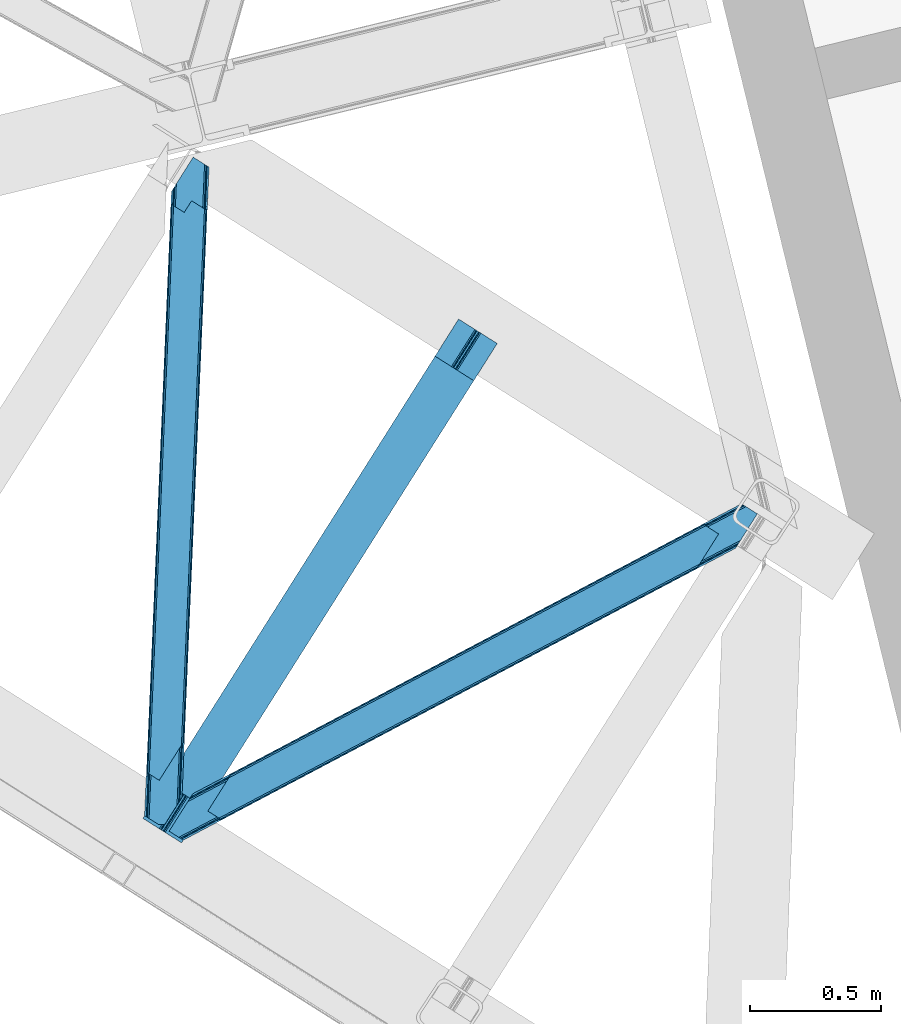
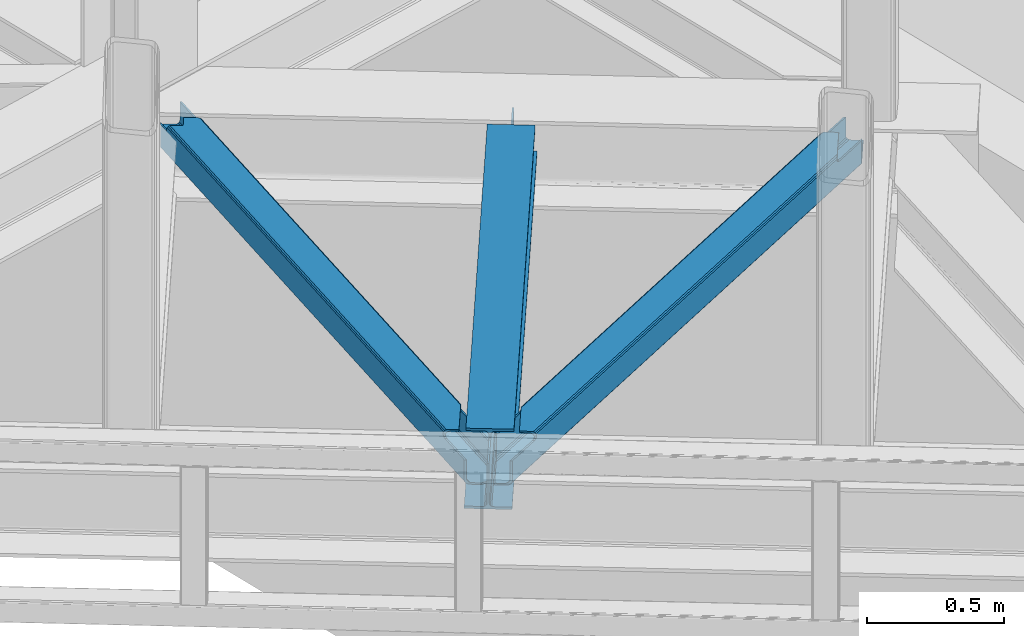
# One storey, part 73 of 92: 2 members, 1 beam.
"""IFC4 building model written with IfcOpenShell, lengths in millimetres."""

import ifcopenshell
import ifcopenshell.guid

model = None  # the IFC model being written
_history = None  # IfcOwnerHistory: only IFC2X3 demands one
_inside = {}  # id of a spatial element -> (the spatial element, [elements in it])
_under = {}  # id of a project, library or spatial element -> (it, [spatial elements below it])
_declared = {}  # id of a project -> (the project, [libraries it declares])
_typed = {}  # id of a type object -> (the type object, [elements of that type])
_made_of = {}  # id of a material, layer set ... -> (it, [elements and type objects made of it])


def new_model(schema):
    """Start an empty IFC model of exactly this schema.

    Asked for "IFC4X3", IfcOpenShell would pick the latest addendum, in which some entities
    have other attributes; the version numbers below select the first issue.
    IFC2X3 requires an IfcOwnerHistory on every rooted entity: one is made here for all.
    """
    global model, _history
    if schema == "IFC4X3":
        model = ifcopenshell.file(schema_version=(4, 3, 0, 0))
    else:
        model = ifcopenshell.file(schema=schema)
    _inside.clear()
    _under.clear()
    _declared.clear()
    _typed.clear()
    _made_of.clear()
    _history = None
    if model.schema == "IFC2X3":
        org = make("IfcOrganization", Name="unknown")
        user = make(
            "IfcPersonAndOrganization",
            ThePerson=make("IfcPerson", FamilyName="unknown"),
            TheOrganization=org,
        )
        app = make(
            "IfcApplication",
            ApplicationDeveloper=org,
            Version="unknown",
            ApplicationFullName="unknown",
            ApplicationIdentifier="unknown",
        )
        _history = make(
            "IfcOwnerHistory",
            OwningUser=user,
            OwningApplication=app,
            ChangeAction="ADDED",
            CreationDate=0,
        )
    return model


def make(cls, **values):
    """One entity of the class cls with the attributes given. An attribute that is None is left unset."""
    return model.create_entity(
        cls, **{name: value for name, value in values.items() if value is not None}
    )


def entity(cls, *values):
    """Any entity or typed value of the class cls, its attributes in the order of the schema. None: left unset."""
    e = model.create_entity(cls)
    for i, value in enumerate(values):
        if value is not None:
            e[i] = value
    return e


def rooted(cls, **values):
    """An entity with a GlobalId (a new one), such as an element, a storey or a relation."""
    return make(cls, GlobalId=ifcopenshell.guid.new(), OwnerHistory=_history, **values)


def si_unit(unit_type, name, prefix=None):
    """IfcSIUnit, for example si_unit("LENGTHUNIT", "METRE", prefix="MILLI")."""
    return make("IfcSIUnit", UnitType=unit_type, Prefix=prefix, Name=name)


def converted_unit(unit_type, name, factor, base, dimensions=None, offset=None):
    """IfcConversionBasedUnit, such as the inch: factor (a typed value) times the base unit."""
    return make(
        "IfcConversionBasedUnit"
        if offset is None
        else "IfcConversionBasedUnitWithOffset",
        ConversionOffset=offset,
        Dimensions=None
        if dimensions is None
        else entity("IfcDimensionalExponents", *dimensions),
        UnitType=unit_type,
        Name=name,
        ConversionFactor=make(
            "IfcMeasureWithUnit", ValueComponent=factor, UnitComponent=base
        ),
    )


def derived_unit(unit_type, elements):
    """IfcDerivedUnit: a product of units, each with its exponent."""
    return make(
        "IfcDerivedUnit",
        Elements=[
            make("IfcDerivedUnitElement", Unit=unit, Exponent=power)
            for unit, power in elements
        ],
        UnitType=unit_type,
    )


def assignment(units):
    """IfcUnitAssignment: the units of a project."""
    return None if units is None else make("IfcUnitAssignment", Units=units)


def point(xyz):
    """IfcCartesianPoint."""
    return None if xyz is None else make("IfcCartesianPoint", Coordinates=xyz)


def direction(xyz):
    """IfcDirection."""
    return None if xyz is None else make("IfcDirection", DirectionRatios=xyz)


def frame(location, z_axis=None, x_axis=None):
    """IfcAxis2Placement3D, a coordinate frame: its origin and axes. An axis left out is left unset."""
    return make(
        "IfcAxis2Placement3D",
        Location=point(location),
        Axis=direction(z_axis),
        RefDirection=direction(x_axis),
    )


def origin():
    """The frame at (0, 0, 0) with its axes left unset."""
    return frame((0.0, 0.0, 0.0))


def place(relative_to, where):
    """IfcLocalPlacement: puts the frame where relative to a parent placement (None: the world)."""
    return make(
        "IfcLocalPlacement", PlacementRelTo=relative_to, RelativePlacement=where
    )


def context(
    kind, dimensions, precision=None, world=None, true_north=None, identifier=None
):
    """IfcGeometricRepresentationContext, for example the 3D "Model" context."""
    return make(
        "IfcGeometricRepresentationContext",
        ContextIdentifier=identifier,
        ContextType=kind,
        CoordinateSpaceDimension=dimensions,
        Precision=precision,
        WorldCoordinateSystem=world,
        TrueNorth=true_north,
    )


def subcontext(parent, identifier, kind, view, scale=None):
    """IfcGeometricRepresentationSubContext, for example "Body" below "Model"."""
    return make(
        "IfcGeometricRepresentationSubContext",
        ContextIdentifier=identifier,
        ContextType=kind,
        ParentContext=parent,
        TargetScale=scale,
        TargetView=view,
    )


def project(units=None, contexts=None):
    """IfcProject with its units and contexts."""
    return rooted(
        "IfcProject",
        Name="project",
        RepresentationContexts=contexts,
        UnitsInContext=assignment(units),
    )


def spatial(cls, under=None, at=None, **own):
    """A site, building, storey or space (cls), placed at a placement, below another one or the project."""
    s = rooted(cls, ObjectPlacement=at, **own)
    if under is not None:
        _under.setdefault(under.id(), (under, []))[1].append(s)
    return s


def point_list(points):
    """IfcCartesianPointList2D or 3D."""
    cls = (
        "IfcCartesianPointList2D" if len(points[0]) == 2 else "IfcCartesianPointList3D"
    )
    return make(cls, CoordList=points)


def triangles(points, corners, closed=None, point_numbers=None):
    """IfcTriangulatedFaceSet: each triangle names its three corners, points numbered from 1."""
    return make(
        "IfcTriangulatedFaceSet",
        Coordinates=point_list(points),
        Closed=closed,
        CoordIndex=corners,
        PnIndex=point_numbers,
    )


def polygons(points, faces, closed=None, point_numbers=None):
    """IfcPolygonalFaceSet: a face is its outer loop, then its inner loops; points numbered from 1."""
    made = []
    for loops in faces:
        if len(loops) == 1:
            made.append(make("IfcIndexedPolygonalFace", CoordIndex=loops[0]))
        else:
            made.append(
                make(
                    "IfcIndexedPolygonalFaceWithVoids",
                    CoordIndex=loops[0],
                    InnerCoordIndices=loops[1:],
                )
            )
    return make(
        "IfcPolygonalFaceSet",
        Coordinates=point_list(points),
        Closed=closed,
        Faces=made,
        PnIndex=point_numbers,
    )


def shape(context_of_items, identifier, shape_type, items):
    """IfcShapeRepresentation: the items that make up one representation, for example the "Body"."""
    return make(
        "IfcShapeRepresentation",
        ContextOfItems=context_of_items,
        RepresentationIdentifier=identifier,
        RepresentationType=shape_type,
        Items=items,
    )


def material(Name=None, Category=None):
    """IfcMaterial."""
    return make("IfcMaterial", Name=Name, Category=Category)


def made_of(thing, what):
    """Note that an element or type object is made of a material, layer set ...; save() writes the relation."""
    if what is not None:
        _made_of.setdefault(what.id(), (what, []))[1].append(thing)
    return thing


def type_object(cls, material=None, **own):
    """A type object (cls), such as IfcWallType, which elements share."""
    return made_of(rooted(cls, **own), material)


def element(
    cls,
    number,
    at=None,
    inside=None,
    cuts=None,
    type_object=None,
    material=None,
    context=None,
    identifier="Body",
    shape_type=None,
    held_by="IfcProductDefinitionShape",
    body=None,
    shapes=None,
    **own,
):
    """One element of the class cls, such as IfcWall. Its Tag is "e" and its number.

    at: its placement. inside: the storey or other place that contains it. cuts: it is an
    opening in that element (IfcRelVoidsElement). A single representation is given by context,
    identifier, shape_type and body (its items); several are given by shapes. held_by: the class
    of the entity that holds the representations. save() writes the other relations.
    """
    e = rooted(cls, Tag="e%d" % number, ObjectPlacement=at, **own)
    if body is not None:
        shapes = [shape(context, identifier, shape_type, body)]
    if shapes is not None:
        e.Representation = make(held_by, Representations=shapes)
    if inside is not None:
        _inside.setdefault(inside.id(), (inside, []))[1].append(e)
    if cuts is not None:
        rooted(
            "IfcRelVoidsElement", RelatingBuildingElement=cuts, RelatedOpeningElement=e
        )
    if type_object is not None:
        _typed.setdefault(type_object.id(), (type_object, []))[1].append(e)
    return made_of(e, material)


def aggregate(whole, parts):
    """IfcRelAggregates: a whole, such as a stair, and the parts it consists of."""
    return rooted("IfcRelAggregates", RelatingObject=whole, RelatedObjects=parts)


def save(model, path):
    """Write the relations noted so far, then the file.

    IfcRelAggregates (storeys below a building ...), IfcRelContainedInSpatialStructure (elements
    in a storey), IfcRelDefinesByType, IfcRelAssociatesMaterial and IfcRelDeclares: one each for
    every whole, place, type object, material and project.
    """
    for whole, parts in _under.values():
        aggregate(whole, parts)
    for where, things in _inside.values():
        rooted(
            "IfcRelContainedInSpatialStructure",
            RelatedElements=things,
            RelatingStructure=where,
        )
    for kind, things in _typed.values():
        rooted("IfcRelDefinesByType", RelatedObjects=things, RelatingType=kind)
    for what, things in _made_of.values():
        rooted("IfcRelAssociatesMaterial", RelatedObjects=things, RelatingMaterial=what)
    for by, libraries in _declared.values():
        rooted("IfcRelDeclares", RelatingContext=by, RelatedDefinitions=libraries)
    model.write(path)


model = new_model("IFC4")

# Units and contexts
model_context = context("Model", 3, precision=0.01, world=origin(), true_north=direction((6.12303176911189e-17, 1.0)))
plan_context = context("Plan", 3, precision=0.01, world=origin(), true_north=direction((6.12303176911189e-17, 1.0)))
body_context = subcontext(model_context, "Body", "Model", "MODEL_VIEW")
ifc_project = project(units=[si_unit("LENGTHUNIT", "METRE", prefix="MILLI"), si_unit("AREAUNIT", "SQUARE_METRE"), si_unit("VOLUMEUNIT", "CUBIC_METRE"), converted_unit("PLANEANGLEUNIT", "DEGREE", entity("IfcRatioMeasure", 0.0174532925199433), si_unit("PLANEANGLEUNIT", "RADIAN"), dimensions=[0, 0, 0, 0, 0, 0, 0]), si_unit("MASSUNIT", "GRAM", prefix="KILO"), derived_unit("MASSDENSITYUNIT", [(si_unit("MASSUNIT", "GRAM", prefix="KILO"), 1), (si_unit("LENGTHUNIT", "METRE"), -3)]), derived_unit("MOMENTOFINERTIAUNIT", [(si_unit("LENGTHUNIT", "METRE"), 4)]), si_unit("TIMEUNIT", "SECOND"), si_unit("FREQUENCYUNIT", "HERTZ"), si_unit("THERMODYNAMICTEMPERATUREUNIT", "DEGREE_CELSIUS"), derived_unit("THERMALTRANSMITTANCEUNIT", [(si_unit("MASSUNIT", "GRAM", prefix="KILO"), 1), (si_unit("THERMODYNAMICTEMPERATUREUNIT", "KELVIN"), -1), (si_unit("TIMEUNIT", "SECOND"), -3)]), derived_unit("VOLUMETRICFLOWRATEUNIT", [(si_unit("LENGTHUNIT", "METRE"), 3), (si_unit("TIMEUNIT", "SECOND"), -1)]), derived_unit("MASSFLOWRATEUNIT", [(si_unit("MASSUNIT", "GRAM", prefix="KILO"), 1), (si_unit("TIMEUNIT", "SECOND"), -1)]), derived_unit("ROTATIONALFREQUENCYUNIT", [(si_unit("TIMEUNIT", "SECOND"), -1)]), si_unit("ELECTRICCURRENTUNIT", "AMPERE"), si_unit("ELECTRICVOLTAGEUNIT", "VOLT"), si_unit("POWERUNIT", "WATT"), si_unit("FORCEUNIT", "NEWTON", prefix="KILO"), si_unit("ILLUMINANCEUNIT", "LUX"), si_unit("LUMINOUSFLUXUNIT", "LUMEN"), si_unit("LUMINOUSINTENSITYUNIT", "CANDELA"), derived_unit("USERDEFINED", [(si_unit("MASSUNIT", "GRAM", prefix="KILO"), -1), (si_unit("LENGTHUNIT", "METRE"), -2), (si_unit("TIMEUNIT", "SECOND"), 3), (si_unit("LUMINOUSFLUXUNIT", "LUMEN"), 1)]), derived_unit("LINEARVELOCITYUNIT", [(si_unit("LENGTHUNIT", "METRE"), 1), (si_unit("TIMEUNIT", "SECOND"), -1)]), si_unit("PRESSUREUNIT", "PASCAL"), derived_unit("USERDEFINED", [(si_unit("LENGTHUNIT", "METRE"), -2), (si_unit("MASSUNIT", "GRAM", prefix="KILO"), 1), (si_unit("TIMEUNIT", "SECOND"), -2)]), derived_unit("LINEARFORCEUNIT", [(si_unit("MASSUNIT", "GRAM", prefix="KILO"), 1), (si_unit("LENGTHUNIT", "METRE"), 1), (si_unit("TIMEUNIT", "SECOND"), -2), (si_unit("LENGTHUNIT", "METRE"), -1)]), derived_unit("PLANARFORCEUNIT", [(si_unit("MASSUNIT", "GRAM", prefix="KILO"), 1), (si_unit("LENGTHUNIT", "METRE"), 1), (si_unit("TIMEUNIT", "SECOND"), -2), (si_unit("LENGTHUNIT", "METRE"), -2)])], contexts=[model_context, plan_context])

# Site, building, storey
site_placement = place(None, origin())
site = spatial("IfcSite", under=ifc_project, at=site_placement, CompositionType="ELEMENT")
building_placement = place(site_placement, origin())
building = spatial("IfcBuilding", under=site, at=building_placement, CompositionType="ELEMENT")
storey_placement = place(building_placement, frame((0.0, 0.0, 15900.0)))
storey = spatial("IfcBuildingStorey", under=building, at=storey_placement, Name="05", CompositionType="ELEMENT", Elevation=15900.0)

# Beam
ifc_material = material(Name="Metal painted (White)")
beam_type = type_object("IfcBeamType", PredefinedType="BEAM")
beam_placement = place(storey_placement, frame((-2373.15, 14260.29, 3441.0)))
element("IfcBeam", 1, at=beam_placement, inside=storey, type_object=beam_type, material=ifc_material, ObjectType="Steel Beam", PredefinedType="BEAM", context=body_context, shape_type="Tessellation", body=[
    polygons([(147.919660694801, 2.16573425859679e-12, 11.000000000004), (147.919660694804, 4.33146851719357e-12, 2.16573425859679e-12), (1355.44607863557, 1910.06544717356, 2.16573425859679e-12), (1355.44607863557, 1910.06544717355, 11.000000000004), (90.4423068248279, 36.3366728266057, 11.0000000000062), (1297.96872476558, 1946.40212000016, 11.0000000000062), (85.2668642219479, 39.6085416920184, 12.2179274798195), (1292.7932821627, 1949.67398886557, 12.2179274798195), (80.879335839855, 42.3822981822298, 15.6862915010278), (1288.40575378062, 1952.44774535578, 15.6862915010235), (77.9476831016699, 44.2356630157985, 20.8770650821592), (1285.47410104242, 1954.30111018934, 20.8770650821592), (76.9182235613, 44.8864781975669, 27.0000000000047), (1284.44464150205, 1954.95192537111, 27.0000000000025), (1278.52785507426, 1958.69246522089, 27.0000000000047), (1278.52785507432, 1958.69246522022, 203.000000000006), (1284.44464150196, 1954.95192537085, 203.000000000006), (1207.52641794078, 2003.57894341848, 2.16573425859679e-12), (1207.52641794077, 2003.57894341847, 10.9999999999997), (1265.00377181074, 1967.24227059188, 11.000000000004), (1270.17921441362, 1963.97040172646, 12.2179274798174), (1274.56674279571, 1961.19664523624, 15.686291501017), (1277.49839553388, 1959.34328040268, 20.8770650821613), (76.9182235613823, 44.8864781975192, 203.000000000006), (71.0014371335516, 48.6270180473361, 203.000000000006), (71.0014371335062, 48.6270180473665, 27.0000000000047), (69.9719775931376, 49.2778332291413, 20.8770650821657), (67.0403248549568, 51.1311980626949, 15.686291501017), (62.6527964728682, 53.904954552915, 12.2179274798174), (57.4773538699869, 57.176823418332, 11.000000000004), (8.12150346973795e-12, 93.5134962449225, 10.9999999999997), (5.41433564649196e-12, 93.5134962449269, 2.16573425859679e-12), (162.887980343835, 180.873386503032, 203.069792575797), (1195.07248712349, 1813.58297531797, 203.006342981534), (1194.53809439775, 1812.73773730252, 217.000000000003), (163.217821525431, 181.395193639939, 217.000000000003), (163.217821525544, 181.395193639874, 204.000000000014), (156.766642341062, 184.290495421957, 203.006342980148), (157.301035097542, 185.135733489758, 217.000000000003), (1188.62130797009, 1816.4782771522, 217.000000000003), (1188.6213079702, 1816.47827715213, 204.00000000001), (1188.95114918025, 1817.00008434255, 203.069791966823), (157.301035097816, 185.135733489578, 204.000000000014), (164.247281065643, 180.744378458268, 223.122934917846), (167.178933803825, 178.891013624723, 228.313708498988), (171.566462185928, 176.117257134518, 231.782072520181), (176.741904788822, 172.845388269138, 232.999999999999), (234.219258658959, 136.508715442803, 233.000000000003), (234.219258658962, 136.508715442803, 244.000000000005), (86.2995979637529, 230.022211687052, 244.000000000005), (86.2995979637521, 230.022211687052, 232.999999999999), (143.776951833897, 193.685538860712, 233.000000000003), (148.952394436777, 190.413669995315, 231.78207252019), (153.339922818875, 187.63991350511, 228.313708498988), (156.271575557062, 185.786548671563, 223.12293491785), (1187.59184842946, 1817.12909233409, 223.12293491785), (1184.66019569129, 1818.98245716763, 228.313708498988), (1180.27266730917, 1821.75621365784, 231.78207252019), (1175.0972247063, 1825.02808252324, 233.000000000003), (1117.61987083616, 1861.36475534957, 232.999999999999), (1117.61987083616, 1861.36475534957, 244.000000000005), (1265.53953153138, 1767.85125910532, 244.000000000005), (1265.53953153137, 1767.85125910532, 233.000000000003), (1208.06217766123, 1804.18793193166, 233.000000000003), (1202.88673505832, 1807.45980079704, 231.782072520181), (1198.49920667623, 1810.23355728724, 228.313708498988), (1195.56755393804, 1812.08692212079, 223.122934917842), (1194.53809439802, 1812.73773730233, 204.00000000001)], [[[1, 2, 3, 4]], [[5, 1, 4, 6]], [[7, 5, 6, 8]], [[9, 7, 8, 10]], [[11, 9, 10, 12]], [[13, 11, 12, 14]], [[15, 16, 17, 14, 12, 10, 8, 6, 4, 3, 18, 19, 20, 21, 22, 23]], [[13, 24, 25, 26, 27, 28, 29, 30, 31, 32, 2, 1, 5, 7, 9, 11]], [[2, 32, 18, 3]], [[32, 31, 19, 18]], [[31, 30, 20, 19]], [[27, 26, 15, 23]], [[28, 27, 23, 22]], [[29, 28, 22, 21]], [[30, 29, 21, 20]], [[33, 24, 13, 14, 17, 34, 35, 36, 37]], [[25, 38, 39, 40, 41, 42, 16, 15, 26]], [[38, 25, 24, 33]], [[42, 34, 17, 16]], [[39, 43, 37, 36, 44, 45, 46, 47, 48, 49, 50, 51, 52, 53, 54, 55]], [[40, 56, 57, 58, 59, 60, 61, 62, 63, 64, 65, 66, 67, 35, 68, 41]], [[44, 36, 35, 67]], [[45, 44, 67, 66]], [[46, 45, 66, 65]], [[47, 46, 65, 64]], [[48, 47, 64, 63]], [[49, 48, 63, 62]], [[50, 49, 62, 61]], [[51, 50, 61, 60]], [[52, 51, 60, 59]], [[53, 52, 59, 58]], [[54, 53, 58, 57]], [[55, 54, 57, 56]], [[39, 55, 56, 40]]], closed=False),
])

# Members
member_type_1 = type_object("IfcMemberType", PredefinedType="BRACE")
member_1_placement = place(storey_placement, frame((-2272.78, 14270.52, 3541.0)))
element("IfcMember", 2, at=member_1_placement, inside=storey, type_object=member_type_1, ObjectType="Steel Horizontal Brace", PredefinedType="BRACE", context=body_context, shape_type="Tessellation", body=[
    triangles([(2166.61486344337, 1116.62719116211, 112.998916625977), (2173.80174307823, 1127.99161376953, 112.998916625977), (2044.4205051899, 1059.94925537109, 112.998916625977), (2036.90270462036, 1048.05812072754, 112.998916625977), (2029.42218375206, 1044.1037109375, 113.836074829102), (2032.01686549187, 1053.39151611328, 115.498764038086), (2030.77495365143, 1052.79155273437, 116.284762573243), (2036.94003882408, 1055.99484558105, 113.836074829102), (2026.93752436638, 1051.31141052246, 119.789199829102), (2018.84619412422, 1038.51219177246, 119.789199829102), (2023.08254528046, 1040.75158996582, 116.221975708009), (2028.56100811958, 1051.72068786621, 117.687002563478), (2026.56859703064, 1052.01950683594, 122.196029663086), (2017.54004201889, 1037.82153625488, 122.500662231447), (2017.42678585053, 1037.83432617187, 124.000570678712), (2027.24235677719, 1053.36012268066, 124.000570678712), (200.000582885742, 78.5370666503895, 129.195602416992), (201.301375579834, 77.717349243163, 122.500662231447), (2018.78793096542, 1039.9888458252, 129.195602416992), (2022.86099267006, 1046.4326385498, 134.874325561523), (196.304878234863, 80.8741333007802, 134.874325561523), (2028.95898528099, 1056.07856140137, 138.667117309571), (190.775273895264, 84.3727569580078, 138.667117309571), (2036.15227804184, 1067.45577392578, 139.999594116212), (184.250090789795, 88.4980865478501, 139.999594116212), (193.497927474975, 81.5101409912095, 114.866244506837), (194.136696624756, 82.2473052978512, 118.998550415039), (192.620655441284, 83.2042236328125, 121.889071655274), (189.485236358642, 85.1866607666016, 127.874752807616), (2030.37881140709, 1058.32493591309, 127.874752807616), (2043.67013311386, 1079.34690856934, 133.000021362306), (2036.47684035301, 1067.96969604492, 131.667544555665), (177.425943374634, 92.8094512939442, 133.000021362306), (183.951126480103, 88.6841217041001, 131.667544555665), (201.301375579834, 77.717349243163, 118.998550415039), (148.082821655273, 111.360644531249, 139.999594116212), (148.082821655273, 111.360644531249, 133.000021362306), (2101.84745049477, 1171.37268676758, 139.999594116212), (2101.84745049477, 1171.37268676758, 133.000021362306), (2059.13757562637, 1198.37336425781, 139.999594116212), (220.991888809204, 226.688488769531, 139.999594116212), (2065.9571993351, 1194.06083679199, 133.000021362306), (213.474033737183, 214.797354125976, 133.000021362306), (226.76537361145, 235.819326782226, 127.874752807616), (228.185199737549, 238.066864013672, 138.667117309571), (220.667344665527, 226.17456665039, 131.667544555665), (234.283228683472, 247.711624145508, 134.874325561523), (229.901810073852, 240.784140014648, 124.000570678712), (238.35623588562, 254.155416870117, 129.195602416992), (239.717344665527, 256.309936523438, 124.000570678712), (2043.38265066147, 1208.33322143555, 129.195602416992), (2042.08625450134, 1209.1541015625, 122.500662231447), (239.604124832153, 256.322726440429, 122.500662231447), (2052.6124288559, 1202.49985656738, 138.667117309571), (2047.07826447487, 1205.99615478516, 134.874325561523), (2053.90241189003, 1201.68479003906, 127.874752807616), (2059.43205256462, 1198.18732910156, 131.667544555665), (2050.76254177094, 1203.66722717285, 121.889071655274), (2049.25095162392, 1204.62414550781, 118.998550415039), (2042.08625450134, 1209.1541015625, 118.998550415039), (230.575606155395, 242.124755859375, 122.196029663086), (2049.88982977867, 1205.36130981445, 114.866244506837), (228.587500762939, 242.424737548827, 117.689328002929), (226.52614402771, 241.474795532225, 116.221975708009), (230.206587982178, 242.832852172851, 119.789199829102), (225.127246856689, 240.752746582031, 115.498764038086), (238.297954559326, 255.632070922851, 119.789199829102), (234.061585235596, 253.392672729491, 116.221975708009), (227.722001266479, 250.040551757811, 113.836074829102), (220.204146194458, 238.149417114257, 113.836074829102), (220.241498565674, 246.087304687499, 112.998916625977), (212.723643493652, 234.195007324219, 112.998916625977), (199.660342025757, 76.8499603271484, 115.110415649415), (198.014802932739, 75.9802459716793, 111.222280883791), (190.089123916626, 71.7909667968743, 107.999221801758), (194.054288864136, 73.8861877441395, 109.610751342774), (187.230141448974, 78.1975524902336, 109.610751342774), (183.269482040405, 76.1034942626939, 107.999221801758), (191.195161056518, 80.2927734374989, 111.222280883791), (2045.36841244698, 1210.89004211426, 111.222280883791), (2043.72734255791, 1210.02265319824, 115.110415649415), (2052.1880361557, 1206.57751464844, 111.222280883791), (2056.15312843323, 1208.6727355957, 109.610751342774), (2049.3335047245, 1212.98526306152, 109.610751342774), (2060.11818437576, 1210.7691192627, 107.999221801758), (2053.2940369606, 1215.08048400879, 107.999221801758), (54.2830238342285, 0.0, 107.999221801758), (47.4635272979735, 4.31252746581958, 107.999221801758), (2166.61486344337, 1116.62719116211, 17.5000946044929), (54.2830238342285, 0.0, 17.5000946044929), (2032.0435353756, 1053.34151916504, 115.498764038086), (2174.14860599041, 1128.49274597168, 24.4996673583992), (191.196323776245, 80.2881225585934, 111.222280883791), (2173.68541660309, 1128.21253051758, 112.998916625977), (2044.44708423615, 1059.89925842285, 112.998916625977), (2174.16452071667, 1128.46716613769, 112.133853149415), (2036.96659970284, 1055.94484863281, 113.836074829102), (47.4478305816651, 4.3381072998036, 24.4996673583992), (183.2703540802, 76.1000061035156, 107.999221801758), (187.235664367676, 78.1940643310536, 109.610751342774), (47.4633819580076, 4.31369018554688, 107.999221801758), (193.499235534668, 81.5043273925767, 114.866244506837), (2185.41397941113, 1146.35793457031, 0.0), (2178.22067756653, 1134.9807220459, 1.33131408691406), (37.2317390441895, 10.7807373046871, 0.0), (43.7569221496583, 6.65540771484302, 1.33131408691406), (2172.12263953686, 1125.33479919434, 5.12526855468604), (49.2910320281981, 3.15910949706995, 5.12526855468604), (2168.04959599972, 1118.89100646973, 10.8028289794929), (52.9867366790772, 0.822042846679324, 10.8028289794929), (2174.1327185154, 1128.51832580566, 24.4996673583992), (2175.56744198799, 1130.78330383301, 17.8024017333992), (46.1670948028564, 5.13457031249891, 17.8024017333992), (47.4635272979735, 4.31252746581958, 24.4996673583992), (2179.64049460888, 1137.22709655762, 12.1248413085923), (42.4668846130371, 7.47047424316406, 12.1248413085923), (2185.7385235548, 1146.87185668945, 8.3320495605476), (36.9372802734374, 10.9679351806626, 8.3320495605476), (2192.93179814816, 1158.25023193359, 6.99957275390625), (30.4120971679686, 15.0932647705067, 6.99957275390625), (2249.93033573627, 1248.41333312988, 6.99957275390625), (2249.93033573627, 1248.41333312988, 0.0), (2174.1327185154, 1128.51832580566, 112.133853149415), (2195.92426629066, 1282.55892333984, 107.999221801758), (2189.1001188755, 1286.87028808594, 107.999221801758), (0.0, 34.3199981689449, 6.99957275390625), (0.0, 34.3199981689449, 0.0), (90.5293579101563, 177.517071533202, 112.998916625977), (83.0115028381347, 165.625936889648, 112.998916625977), (2189.1001188755, 1286.87028808594, 17.5000946044929), (90.5293579101563, 177.517071533202, 17.5000946044929), (2206.15144000053, 1276.08955078125, 0.0), (71.730214691162, 147.786328124999, 0.0), (2190.40098423958, 1286.05057067871, 10.8028289794929), (89.0945617675779, 175.253256225586, 10.8028289794929), (2194.09663438797, 1283.71350402832, 5.12526855468604), (85.0214092254637, 168.809463500977, 5.12526855468604), (2199.62629323006, 1280.21488037109, 1.33131408691406), (78.9233802795411, 159.163540649413, 1.33131408691406), (2200.91626263857, 1279.4009765625, 12.1248413085923), (2212.97554653883, 1271.77818603516, 6.99957275390625), (2206.45043610334, 1275.903515625, 8.3320495605476), (2195.92426629066, 1282.55892333984, 24.4996673583992), (2197.2206079483, 1281.73804321289, 17.8024017333992), (83.0115028381347, 165.625936889648, 24.4996673583992), (81.5767066955564, 163.360958862304, 17.8024017333992), (77.503699493408, 156.917166137695, 12.1248413085923), (64.2123596191404, 135.894030761718, 6.99957275390625), (71.4056705474854, 147.272406005859, 8.3320495605476)], [[1, 2, 3], [3, 4, 1], [5, 6, 7], [5, 8, 6], [9, 10, 11], [11, 7, 12], [13, 14, 10], [13, 15, 14], [10, 9, 13], [13, 16, 15], [11, 12, 9], [7, 11, 5], [3, 8, 4], [5, 4, 8], [15, 17, 18], [18, 14, 15], [15, 19, 17], [19, 20, 21], [21, 17, 19], [20, 22, 23], [23, 21, 20], [22, 24, 25], [25, 23, 22], [26, 9, 12], [7, 6, 26], [26, 12, 7], [9, 26, 27], [27, 13, 9], [27, 28, 13], [29, 30, 16], [16, 28, 29], [16, 13, 28], [31, 32, 33], [34, 33, 32], [32, 30, 34], [29, 34, 30], [21, 29, 23], [28, 17, 18], [18, 35, 27], [27, 28, 18], [29, 17, 28], [21, 17, 29], [34, 25, 23], [23, 29, 34], [34, 33, 25], [33, 36, 25], [37, 36, 33], [32, 22, 30], [38, 31, 39], [31, 38, 24], [32, 24, 22], [32, 31, 24], [20, 16, 30], [22, 20, 30], [16, 20, 19], [15, 16, 19], [24, 40, 41], [24, 38, 40], [41, 25, 24], [36, 25, 41], [42, 31, 43], [31, 42, 39], [33, 43, 31], [37, 43, 33], [44, 45, 46], [47, 48, 49], [44, 47, 45], [49, 48, 50], [47, 44, 48], [46, 45, 41], [36, 43, 41], [37, 43, 36], [43, 46, 41], [50, 51, 52], [52, 53, 50], [40, 54, 45], [45, 41, 40], [54, 55, 47], [47, 45, 54], [55, 51, 49], [49, 47, 55], [50, 49, 51], [56, 54, 55], [39, 38, 42], [38, 40, 42], [54, 57, 40], [56, 57, 54], [57, 42, 40], [51, 58, 56], [55, 51, 56], [58, 51, 52], [52, 59, 58], [52, 60, 59], [56, 44, 48], [48, 58, 56], [48, 61, 58], [62, 63, 64], [62, 65, 63], [64, 66, 62], [65, 62, 59], [59, 61, 65], [59, 58, 61], [56, 57, 44], [46, 44, 57], [57, 42, 46], [43, 46, 42], [61, 53, 67], [61, 50, 53], [67, 65, 61], [65, 67, 68], [68, 64, 63], [69, 66, 64], [69, 70, 66], [69, 71, 70], [72, 70, 71], [64, 68, 69], [68, 63, 65], [61, 48, 50], [27, 26, 73], [73, 35, 27], [74, 73, 26], [75, 76, 77], [77, 78, 75], [76, 74, 79], [79, 77, 76], [26, 79, 74], [80, 81, 62], [59, 62, 81], [81, 60, 59], [62, 82, 80], [82, 83, 84], [84, 80, 82], [83, 85, 86], [86, 84, 83], [75, 78, 87], [88, 87, 78], [11, 74, 89], [11, 10, 74], [14, 74, 10], [35, 73, 14], [35, 14, 18], [5, 11, 89], [89, 1, 4], [4, 5, 89], [90, 89, 74], [74, 14, 73], [74, 76, 90], [75, 90, 76], [90, 75, 87], [91, 92, 93], [94, 92, 95], [94, 96, 92], [91, 97, 92], [97, 95, 92], [93, 92, 98], [98, 99, 100], [98, 101, 99], [100, 93, 98], [93, 102, 91], [103, 104, 105], [106, 105, 104], [104, 107, 106], [108, 106, 107], [107, 109, 108], [110, 108, 109], [109, 89, 110], [90, 110, 89], [111, 112, 113], [113, 114, 111], [112, 115, 116], [116, 113, 112], [115, 117, 118], [118, 116, 115], [117, 119, 120], [120, 118, 117], [115, 107, 104], [115, 104, 117], [119, 117, 103], [112, 107, 115], [121, 119, 122], [103, 122, 119], [117, 104, 103], [109, 107, 112], [1, 89, 111], [111, 123, 1], [2, 1, 123], [109, 112, 89], [112, 111, 89], [124, 125, 85], [86, 85, 125], [110, 116, 108], [114, 90, 87], [87, 88, 114], [114, 113, 90], [113, 110, 90], [116, 110, 113], [106, 108, 116], [120, 105, 118], [116, 118, 106], [120, 126, 127], [118, 105, 106], [120, 127, 105], [72, 71, 128], [128, 129, 72], [80, 130, 131], [84, 130, 80], [125, 130, 86], [84, 86, 130], [60, 81, 53], [81, 80, 53], [52, 60, 53], [68, 80, 131], [131, 69, 68], [71, 69, 131], [131, 128, 71], [68, 67, 80], [67, 53, 80], [132, 103, 133], [103, 132, 122], [105, 133, 103], [127, 133, 105], [130, 134, 131], [135, 131, 134], [134, 136, 135], [137, 135, 136], [136, 138, 137], [139, 137, 138], [138, 132, 139], [133, 139, 132], [140, 138, 136], [121, 122, 141], [122, 132, 141], [138, 142, 132], [140, 142, 138], [142, 141, 132], [130, 143, 144], [134, 140, 136], [140, 134, 144], [134, 130, 144], [125, 143, 130], [125, 124, 143], [143, 82, 145], [83, 82, 143], [82, 62, 66], [143, 85, 83], [85, 143, 124], [145, 82, 66], [66, 70, 145], [72, 145, 70], [145, 72, 129], [137, 146, 147], [145, 131, 128], [128, 129, 145], [145, 146, 131], [146, 135, 131], [146, 137, 135], [139, 137, 147], [148, 133, 149], [147, 149, 139], [148, 126, 127], [149, 133, 139], [148, 127, 133], [119, 141, 148], [119, 121, 141], [148, 120, 119], [126, 120, 148], [141, 142, 149], [149, 148, 141], [142, 140, 147], [147, 149, 142], [140, 144, 146], [146, 147, 140], [144, 143, 145], [145, 146, 144]]),
])
member_type_2 = type_object("IfcMemberType", PredefinedType="BRACE")
member_2_placement = place(storey_placement, frame((-2366.79, 14329.55, 3541.0)))
element("IfcMember", 3, at=member_2_placement, inside=storey, type_object=member_type_2, ObjectType="Steel Horizontal Brace", PredefinedType="BRACE", context=body_context, shape_type="Tessellation", body=[
    triangles([(100.655629348755, 2374.38995361328, 112.998916625977), (107.475271224976, 2370.07742614746, 112.998916625977), (102.696783828736, 2421.82891845703, 112.998916625977), (109.879194259644, 2433.19217834473, 112.998916625977), (110.120894622803, 2433.18287658691, 112.998916625977), (107.407542800903, 2370.08091430664, 112.998916625977), (110.142259597778, 2433.72354125977, 112.133853149415), (107.407397460938, 2370.08091430664, 115.498764038086), (13.930835723877, 195.896182250977, 115.498764038086), (110.180774688721, 2433.72237854004, 24.4996673583992), (13.8035179138183, 192.844042968751, 111.222280883791), (6.85336074829092, 30.4120971679695, 24.4996673583992), (13.6123958587646, 188.365246582032, 109.610751342774), (13.4169136047362, 183.884124755859, 107.999221801758), (6.81949653625497, 30.4144226074222, 107.999221801758), (0.0, 34.7257873535164, 107.999221801758), (6.82414741516141, 30.4144226074222, 107.999221801758), (13.4262153625491, 183.885287475587, 107.999221801758), (6.6020679473877, 188.196652221681, 107.999221801758), (6.98896293640155, 197.155407714845, 111.222280883791), (13.808604812622, 192.842880249023, 111.222280883791), (13.9405735015871, 195.89501953125, 115.498764038086), (14.3164226531985, 196.336853027344, 118.998550415039), (7.14723815917978, 200.865646362305, 118.998550415039), (7.06817321777362, 199.011108398438, 115.110415649415), (13.6174827575683, 188.364083862305, 109.610751342774), (6.79784088134784, 192.676611328125, 109.610751342774), (15.8281036376952, 195.378771972657, 121.889071655274), (108.771703720093, 2369.25654602051, 122.196029663086), (112.471768569947, 2366.92064208984, 127.874752807616), (107.475271224976, 2370.07742614746, 115.498764038086), (18.9633773803712, 193.396334838868, 127.874752807616), (118.001518249512, 2363.42318115235, 131.667544555665), (24.4974872589114, 189.900036621095, 131.667544555665), (124.526556015015, 2359.29668884277, 133.000021362306), (31.0226703643798, 185.773544311523, 133.000021362306), (129.009131240845, 2463.45079650879, 6.99957275390625), (121.8158203125, 2452.07358398438, 8.3320495605476), (23.8754322052005, 19.6336853027351, 6.99957275390625), (17.3502490997316, 23.7590148925792, 8.3320495605476), (115.717791366577, 2442.42882385254, 12.1248413085923), (11.8161392211914, 27.2564758300778, 12.1248413085923), (111.644784164429, 2435.9838684082, 17.8024017333992), (8.12043457031268, 29.5935424804684, 17.8024017333992), (110.214638900757, 2433.72121582031, 24.4996673583992), (6.82414741516141, 30.4144226074222, 24.4996673583992), (102.696783828736, 2421.82891845703, 17.5000946044929), (100.655629348755, 2374.38995361328, 122.500662231447), (7.14723815917978, 200.865646362305, 122.500662231447), (0.0, 34.7257873535164, 17.5000946044929), (117.706914138794, 2363.6092163086, 139.999594116212), (111.181876373291, 2367.73570861817, 138.667117309571), (17.6778453826905, 194.212564086914, 138.667117309571), (24.2030284881594, 190.086071777345, 139.999594116212), (105.647621154785, 2371.23200683594, 134.874325561523), (12.1437355041503, 197.708862304688, 134.874325561523), (101.952061843872, 2373.56907348633, 129.195602416992), (8.44817619323749, 200.045928955078, 129.195602416992), (151.68507270813, 2342.12680664063, 133.000021362306), (151.68507270813, 2342.12680664063, 139.999594116212), (56.1432300567626, 169.89428100586, 133.000021362306), (56.1432300567626, 169.89428100586, 139.999594116212), (104.126929092407, 2424.09273376465, 10.8028289794929), (1.30093803405771, 33.9060699462898, 10.8028289794929), (108.200081634522, 2430.53652648926, 5.12526855468604), (4.99649734497098, 31.5690032958992, 5.12526855468604), (114.298110580444, 2440.18244934082, 1.33131408691406), (10.5307525634767, 28.0715423583988, 1.33131408691406), (121.491276168823, 2451.55966186523, 0.0), (17.0557903289796, 23.9462127685547, 0.0), (186.00768699646, 2553.61506042481, 6.99957275390625), (186.00768699646, 2553.61506042481, 0.0), (110.214638900757, 2433.72121582031, 112.133853149415), (53.3593883514404, 0.995288085938228, 6.99957275390625), (53.3593883514404, 0.995288085938228, 0.0), (76.5082660675048, 0.0, 0.0), (76.5082660675048, 0.0, 6.99957275390625), (124.379326629639, 75.7232849121101, 0.0), (229.786700820923, 2525.94000549316, 0.0), (116.861471557617, 63.8309875488285, 6.99957275390625), (222.967058944702, 2530.25253295898, 6.99957275390625), (236.311738586426, 2521.8135131836, 1.33131408691406), (131.572637557983, 87.1004974365242, 1.33131408691406), (241.845993804932, 2518.31721496582, 5.12526855468604), (137.670666503906, 96.7452575683601, 5.12526855468604), (245.541553115845, 2515.98014831543, 10.8028289794929), (141.743673706055, 103.190213012696, 10.8028289794929), (246.837985610962, 2515.15926818848, 17.5000946044929), (143.173964309693, 105.452865600586, 17.5000946044929), (240.018343734741, 2519.4717956543, 24.4996673583992), (238.721911239624, 2520.29267578125, 17.8024017333992), (135.656109237671, 93.5605682373043, 24.4996673583992), (134.225963973999, 91.2979156494148, 17.8024017333992), (235.026351928711, 2522.62974243164, 12.1248413085923), (130.152811431885, 84.8529602050785, 12.1248413085923), (229.492096710205, 2526.12604064941, 8.3320495605476), (124.054782485962, 75.2082000732426, 8.3320495605476), (143.173964309693, 105.452865600586, 107.999221801758), (135.656109237671, 93.5605682373043, 107.999221801758), (246.837985610962, 2515.15926818848, 107.999221801758), (240.018343734741, 2519.4717956543, 107.999221801758), (144.900748443604, 308.420709228516, 107.999221801758), (152.418603515625, 320.313006591798, 107.999221801758), (233.416130447388, 2366.00093078613, 107.999221801758), (240.235772323609, 2361.68840332031, 107.999221801758), (233.02938079834, 2357.04217529297, 111.222280883791), (233.225008392334, 2361.52213439942, 109.610751342774), (232.901917648316, 2353.99003601074, 115.498764038086), (144.985917663574, 310.428726196289, 108.999160766602), (144.943333053589, 309.42413635254, 108.49919128418), (144.985917663574, 310.428726196289, 115.498764038086), (143.555627059937, 308.164910888672, 122.196029663086), (152.50362739563, 322.321023559571, 122.500662231447), (151.073482131958, 320.057208251954, 129.195602416992), (147.00047492981, 313.613415527345, 134.874325561523), (139.482619857788, 301.721118164063, 127.874752807616), (152.50362739563, 322.321023559571, 108.999160766602), (140.902445983887, 303.967492675782, 138.667117309571), (133.384590911865, 292.076358032227, 131.667544555665), (133.709135055542, 292.590280151368, 139.999594116212), (126.19127998352, 280.697982788086, 133.000021362306), (239.853528213501, 2352.73081054688, 111.222280883791), (239.774317932129, 2350.87510986328, 115.110415649415), (240.044650268555, 2357.20960693359, 109.610751342774), (239.690747451783, 2349.01940917969, 118.998550415039), (239.690747451783, 2349.01940917969, 122.500662231447), (152.461188125611, 321.316433715821, 108.49919128418), (222.639462661743, 2359.80014648438, 139.999594116212), (179.929569625855, 2386.80082397461, 139.999594116212), (215.819820785523, 2364.1126739502, 133.000021362306), (179.929569625855, 2386.80082397461, 133.000021362306), (234.698755645752, 2352.17735595703, 134.874325561523), (227.879113769531, 2356.48988342285, 127.874752807616), (229.164500427246, 2355.67365417481, 138.667117309571), (231.014387512207, 2354.50628356934, 121.889071655274), (238.394314956665, 2349.84028930664, 129.195602416992), (232.526068496704, 2353.54936523438, 118.998550415039), (222.344858551025, 2359.98618164063, 131.667544555665)], [[1, 2, 3], [4, 3, 2], [5, 6, 7], [6, 8, 9], [6, 10, 7], [6, 11, 10], [9, 11, 6], [12, 10, 11], [13, 12, 11], [12, 13, 14], [15, 12, 14], [16, 17, 18], [18, 19, 16], [20, 21, 22], [23, 24, 25], [25, 22, 23], [22, 25, 20], [26, 21, 27], [20, 27, 21], [18, 26, 19], [27, 19, 26], [28, 29, 30], [29, 28, 23], [23, 31, 29], [23, 22, 31], [30, 32, 28], [30, 33, 32], [34, 32, 33], [33, 35, 34], [36, 34, 35], [37, 38, 39], [40, 39, 38], [38, 41, 40], [42, 40, 41], [41, 43, 42], [44, 42, 43], [43, 45, 44], [46, 44, 45], [1, 25, 24], [47, 20, 1], [1, 3, 47], [24, 48, 1], [49, 48, 24], [20, 47, 50], [50, 19, 27], [50, 16, 19], [27, 20, 50], [20, 25, 1], [51, 52, 53], [53, 54, 51], [52, 55, 56], [56, 53, 52], [55, 57, 58], [58, 56, 55], [57, 48, 49], [49, 58, 57], [30, 52, 55], [59, 60, 35], [60, 51, 35], [52, 33, 51], [30, 33, 52], [33, 35, 51], [48, 31, 29], [57, 30, 55], [30, 57, 29], [57, 48, 29], [1, 31, 48], [1, 2, 31], [32, 53, 56], [61, 62, 36], [62, 54, 36], [53, 34, 54], [32, 34, 53], [34, 36, 54], [58, 28, 32], [56, 58, 32], [28, 58, 49], [49, 23, 28], [49, 24, 23], [47, 63, 64], [64, 50, 47], [63, 65, 66], [66, 64, 63], [65, 67, 68], [68, 66, 65], [67, 69, 70], [70, 68, 67], [41, 65, 67], [41, 67, 38], [37, 38, 69], [43, 65, 41], [71, 37, 72], [69, 72, 37], [38, 67, 69], [63, 65, 43], [3, 47, 45], [45, 73, 3], [4, 3, 73], [63, 43, 47], [43, 45, 47], [68, 42, 66], [40, 70, 39], [74, 39, 75], [40, 42, 68], [39, 70, 75], [40, 68, 70], [64, 66, 42], [16, 50, 46], [44, 46, 50], [17, 16, 46], [42, 44, 64], [44, 50, 64], [76, 77, 75], [74, 75, 77], [70, 78, 75], [78, 70, 69], [76, 75, 78], [69, 79, 78], [79, 69, 72], [74, 77, 80], [39, 80, 37], [80, 39, 74], [81, 37, 80], [81, 71, 37], [79, 82, 83], [83, 78, 79], [82, 84, 85], [85, 83, 82], [84, 86, 87], [87, 85, 84], [86, 88, 89], [89, 87, 86], [90, 91, 92], [93, 92, 91], [91, 94, 93], [95, 93, 94], [94, 96, 95], [97, 95, 96], [96, 81, 97], [80, 97, 81], [85, 93, 95], [92, 89, 98], [98, 99, 92], [92, 93, 89], [93, 87, 89], [93, 85, 87], [83, 85, 95], [80, 78, 97], [95, 97, 83], [80, 77, 76], [97, 78, 83], [80, 76, 78], [91, 90, 88], [88, 86, 91], [94, 86, 84], [86, 94, 91], [90, 100, 88], [90, 101, 100], [94, 84, 82], [96, 82, 79], [72, 81, 79], [71, 81, 72], [81, 96, 79], [96, 94, 82], [99, 98, 102], [103, 102, 98], [104, 105, 100], [100, 101, 104], [106, 90, 102], [104, 90, 107], [104, 101, 90], [108, 106, 109], [106, 107, 90], [110, 109, 106], [92, 102, 90], [92, 99, 102], [102, 110, 106], [109, 111, 108], [112, 111, 113], [113, 114, 112], [115, 112, 114], [112, 115, 116], [111, 117, 113], [111, 109, 117], [116, 115, 118], [119, 118, 120], [62, 121, 120], [61, 121, 62], [121, 119, 120], [119, 116, 118], [88, 122, 117], [123, 117, 122], [124, 122, 88], [88, 105, 124], [105, 88, 100], [103, 89, 88], [113, 125, 126], [88, 117, 127], [123, 125, 117], [117, 125, 113], [88, 127, 103], [89, 103, 98], [120, 51, 60], [51, 120, 54], [62, 54, 120], [60, 128, 120], [128, 60, 129], [121, 35, 59], [35, 121, 36], [61, 36, 121], [59, 130, 121], [130, 59, 131], [132, 133, 134], [135, 136, 126], [126, 125, 137], [137, 135, 126], [133, 136, 135], [132, 136, 133], [138, 128, 134], [134, 133, 138], [138, 130, 128], [130, 129, 128], [131, 129, 130], [133, 135, 112], [135, 137, 111], [111, 112, 135], [137, 108, 111], [112, 116, 133], [138, 133, 116], [116, 119, 138], [130, 138, 119], [119, 121, 130], [137, 125, 123], [122, 106, 108], [124, 105, 107], [104, 107, 105], [122, 124, 106], [107, 106, 124], [108, 123, 122], [123, 108, 137], [126, 136, 113], [114, 113, 136], [136, 132, 114], [115, 114, 132], [132, 134, 115], [118, 115, 134], [134, 128, 118], [120, 118, 128], [129, 131, 59], [59, 60, 129]]),
])

save(model, "model.ifc")
